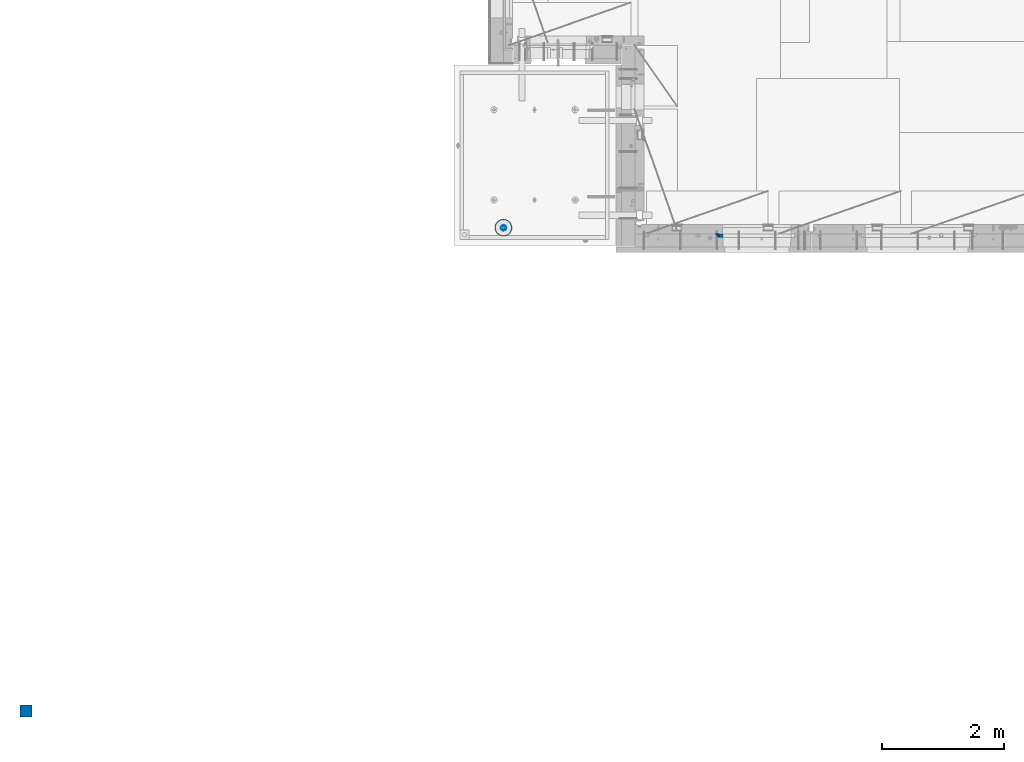
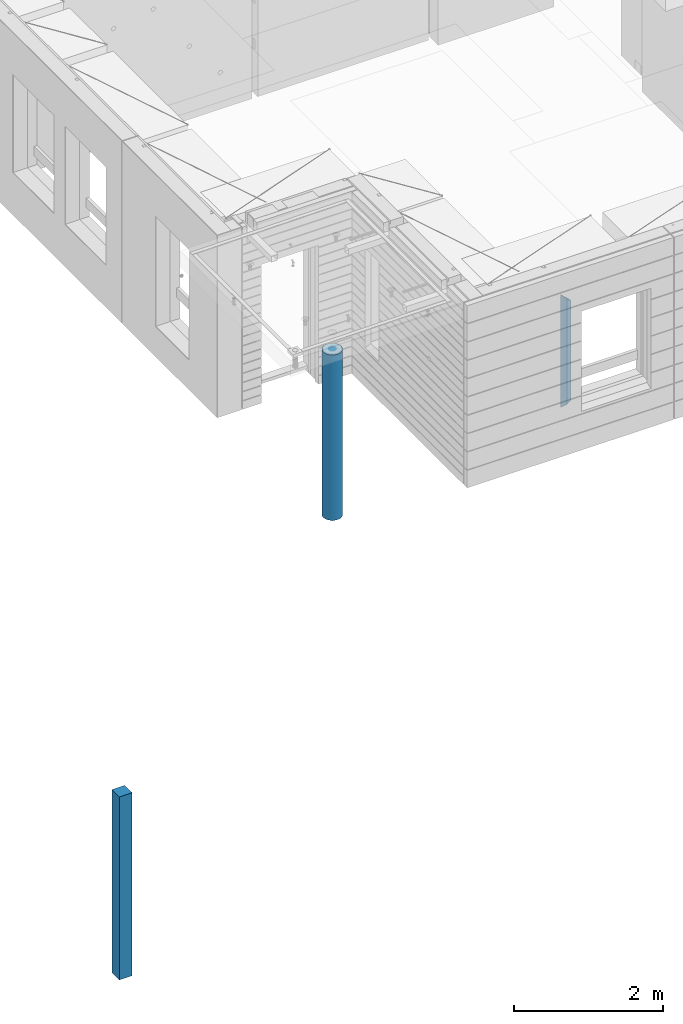
# One storey, part 1 of 349: 4 columns, 3 elements without a shape of their own.
"""IFC2X3 building model written with IfcOpenShell, lengths in millimetres."""

from ifc_helpers import new_model, si_unit, frame, origin_with_axes, place, context, subcontext, project, spatial, faceted_brep, material, type_object, element, aggregate, save


model = new_model("IFC2X3")

# Units and contexts
model_context = context("Model", 3, precision=1e-05, world=origin_with_axes())
body_context = subcontext(model_context, "Body", "Model", "MODEL_VIEW")
ifc_project = project(units=[si_unit("LENGTHUNIT", "METRE", prefix="MILLI"), si_unit("AREAUNIT", "SQUARE_METRE"), si_unit("VOLUMEUNIT", "CUBIC_METRE"), si_unit("MASSUNIT", "GRAM", prefix="KILO"), si_unit("TIMEUNIT", "SECOND"), si_unit("PLANEANGLEUNIT", "RADIAN"), si_unit("SOLIDANGLEUNIT", "STERADIAN"), si_unit("THERMODYNAMICTEMPERATUREUNIT", "DEGREE_CELSIUS"), si_unit("LUMINOUSINTENSITYUNIT", "LUMEN")], contexts=[model_context])

# Site, building, storey
site_placement = place(None, origin_with_axes())
site = spatial("IfcSite", under=ifc_project, at=site_placement, CompositionType="ELEMENT")
building_placement = place(site_placement, origin_with_axes())
building = spatial("IfcBuilding", under=site, at=building_placement, CompositionType="ELEMENT")
storey_placement = place(building_placement, origin_with_axes())
storey = spatial("IfcBuildingStorey", under=building, at=storey_placement, Name="4", CompositionType="ELEMENT", Elevation=0.0)

# Assembly, columns
assembly_1_placement = place(storey_placement, origin_with_axes())
assembly_1 = element("IfcElementAssembly", 1, at=assembly_1_placement, inside=storey, AssemblyPlace="NOTDEFINED", PredefinedType="REINFORCEMENT_UNIT")
ifc_material_1 = material(Name="CONCRETE/C25/30")
column_type_1 = type_object("IfcColumnType", PredefinedType="NOTDEFINED")
column_1_placement = place(assembly_1_placement, frame((11363.0000473781, 7820.0, 91320.0), z_axis=(1.0, 0.0, 0.0), x_axis=(0.0, 0.0, 1.0)))
column_1 = element("IfcColumn", 2, at=column_1_placement, type_object=column_type_1, material=ifc_material_1, Name="SK", context=body_context, shape_type="Brep", body=[
    faceted_brep([(1795.00000000001, -30.0, 30.0), (1855.0, -30.0, -30.0), (1795.00000000001, 30.0, 30.0), (60.0000000000073, -30.0, 30.0), (0.0, -30.0, -30.0), (60.0000000000073, 30.0, 30.0)], [[[0, 1, 2]], [[1, 0, 3, 4]], [[2, 1, 4, 5]], [[0, 2, 5, 3]], [[5, 4, 3]]]),
])
column_type_2 = type_object("IfcColumnType", PredefinedType="NOTDEFINED")
column_2_placement = place(assembly_1_placement, frame((11428.0000473781, 7820.0, 91380.0), z_axis=(1.0, 0.0, 0.0), x_axis=(0.0, 0.0, 1.0)))
column_2 = element("IfcColumn", 3, at=column_2_placement, type_object=column_type_2, material=ifc_material_1, Name="SK", context=body_context, shape_type="Brep", body=[
    faceted_brep([(1735.0, -30.0, -35.0), (1735.0, 30.0, -35.0), (1678.70623674487, 30.0, 30.6760571454033), (1680.09619813452, -30.0, 29.0544355237798), (56.2937632551329, 29.9999988381387, 30.6760571454033), (54.9038019193104, -29.9999988381387, 29.0544355865859), (0.0, -30.0, -35.0), (0.0, 30.0, -35.0)], [[[0, 1, 2, 3]], [[3, 2, 4, 5]], [[0, 3, 5, 6]], [[1, 0, 6, 7]], [[2, 1, 7, 4]], [[5, 4, 7, 6]]]),
])
aggregate(assembly_1, [column_2, column_1])

# Assembly, column
assembly_2_placement = place(storey_placement, origin_with_axes())
assembly_2 = element("IfcElementAssembly", 4, at=assembly_2_placement, inside=storey, AssemblyPlace="NOTDEFINED", PredefinedType="REINFORCEMENT_UNIT")
ifc_material_2 = material(Name="CONCRETE/Concrete_Undefined")
column_type_3 = type_object("IfcColumnType", PredefinedType="NOTDEFINED")
column_3_placement = place(assembly_2_placement, frame((0.0, 0.0, 90760.0), z_axis=(0.0, 1.0, 0.0), x_axis=(0.0, 0.0, 1.0)))
column_3 = element("IfcColumn", 5, at=column_3_placement, type_object=column_type_3, material=ifc_material_2, context=body_context, shape_type="Brep", body=[
    faceted_brep([(0.0, 100.0, -100.0), (0.0, 100.0, 100.0), (3000.0, 100.0, 100.0), (3000.0, 100.0, -100.0), (0.0, -100.0, 100.0), (3000.0, -100.0, 100.0), (0.0, -100.0, -100.0), (3000.0, -100.0, -100.0)], [[[0, 1, 2, 3]], [[1, 4, 5, 2]], [[4, 6, 7, 5]], [[6, 0, 3, 7]], [[5, 7, 3, 2]], [[6, 4, 1, 0]]]),
])
aggregate(assembly_2, [column_3])

assembly_3_placement = place(storey_placement, origin_with_axes())
assembly_3 = element("IfcElementAssembly", 6, at=assembly_3_placement, inside=storey, AssemblyPlace="NOTDEFINED", PredefinedType="REINFORCEMENT_UNIT")
ifc_material_3 = material(Name="CONCRETE/C30/37")
column_type_4 = type_object("IfcColumnType", Name="D280", PredefinedType="NOTDEFINED")
column_4_placement = place(assembly_3_placement, frame((7849.99879520436, 7949.98488883804, 90725.0), z_axis=(-1.0, 3.00000001838171e-08, 0.0), x_axis=(0.0, 0.0, 1.0)))
column_4 = element("IfcColumn", 7, at=column_4_placement, type_object=column_type_4, material=ifc_material_3, ObjectType="D280", context=body_context, shape_type="Brep", body=[
    faceted_brep([(0.0, -140.0, 0.0), (0.0, -136.489907705454, -31.1529307538876), (2710.0, -136.489907705454, -31.1529307538876), (2710.0, -140.0, 0.0), (0.0, -126.135641506338, -60.7437234764584), (2710.0, -126.135641506338, -60.7437234764584), (0.0, -109.456407545524, -87.2885722602223), (2710.0, -109.456407545524, -87.2885722602223), (0.0, -87.2885722602223, -109.456407545527), (2710.0, -87.2885722602223, -109.456407545527), (0.0, -60.7437234764584, -126.135641506342), (2710.0, -60.7437234764584, -126.135641506342), (0.0, -31.152930753884, -136.489907705458), (2710.0, -31.152930753884, -136.489907705458), (0.0, 0.0, -140.0), (2710.0, 0.0, -140.0), (0.0, 31.152930753884, -136.489907705458), (2710.0, 31.152930753884, -136.489907705458), (0.0, 60.7437234764584, -126.135641506342), (2710.0, 60.7437234764584, -126.135641506342), (0.0, 87.2885722602223, -109.456407545527), (2710.0, 87.2885722602223, -109.456407545527), (0.0, 109.456407545524, -87.2885722602223), (2710.0, 109.456407545524, -87.2885722602223), (0.0, 126.135641506338, -60.7437234764584), (2710.0, 126.135641506338, -60.7437234764584), (0.0, 136.489907705454, -31.1529307538876), (2710.0, 136.489907705454, -31.1529307538876), (0.0, 140.0, 0.0), (2710.0, 140.0, 0.0), (0.0, 136.489907705454, 31.1529307538876), (2710.0, 136.489907705454, 31.1529307538876), (0.0, 126.135641506338, 60.7437234764584), (2710.0, 126.135641506338, 60.7437234764584), (0.0, 109.456407545524, 87.2885722602223), (2710.0, 109.456407545524, 87.2885722602223), (0.0, 87.2885722602223, 109.456407545527), (2710.0, 87.2885722602223, 109.456407545527), (0.0, 60.7437234764584, 126.135641506342), (2710.0, 60.7437234764584, 126.135641506342), (0.0, 31.152930753884, 136.489907705458), (2710.0, 31.152930753884, 136.489907705458), (0.0, 0.0, 140.0), (2710.0, 0.0, 140.0), (0.0, -31.152930753884, 136.489907705458), (2710.0, -31.152930753884, 136.489907705458), (0.0, -60.7437234764584, 126.135641506342), (2710.0, -60.7437234764584, 126.135641506342), (0.0, -87.2885722602223, 109.456407545527), (2710.0, -87.2885722602223, 109.456407545527), (0.0, -109.456407545524, 87.2885722602223), (2710.0, -109.456407545524, 87.2885722602223), (0.0, -126.135641506338, 60.7437234764584), (2710.0, -126.135641506338, 60.7437234764584), (0.0, -136.489907705454, 31.1529307538876), (2710.0, -136.489907705454, 31.1529307538876)], [[[0, 1, 2, 3]], [[1, 4, 5, 2]], [[4, 6, 7, 5]], [[6, 8, 9, 7]], [[8, 10, 11, 9]], [[10, 12, 13, 11]], [[12, 14, 15, 13]], [[14, 16, 17, 15]], [[16, 18, 19, 17]], [[18, 20, 21, 19]], [[20, 22, 23, 21]], [[22, 24, 25, 23]], [[24, 26, 27, 25]], [[26, 28, 29, 27]], [[28, 30, 31, 29]], [[30, 32, 33, 31]], [[32, 34, 35, 33]], [[34, 36, 37, 35]], [[36, 38, 39, 37]], [[38, 40, 41, 39]], [[40, 42, 43, 41]], [[42, 44, 45, 43]], [[44, 46, 47, 45]], [[46, 48, 49, 47]], [[48, 50, 51, 49]], [[50, 52, 53, 51]], [[52, 54, 55, 53]], [[54, 0, 3, 55]], [[5, 7, 9, 11, 13, 15, 17, 19, 21, 23, 25, 27, 29, 31, 33, 35, 37, 39, 41, 43, 45, 47, 49, 51, 53, 55, 3, 2]], [[54, 52, 50, 48, 46, 44, 42, 40, 38, 36, 34, 32, 30, 28, 26, 24, 22, 20, 18, 16, 14, 12, 10, 8, 6, 4, 1, 0]]]),
])
aggregate(assembly_3, [column_4])

save(model, "model.ifc")
